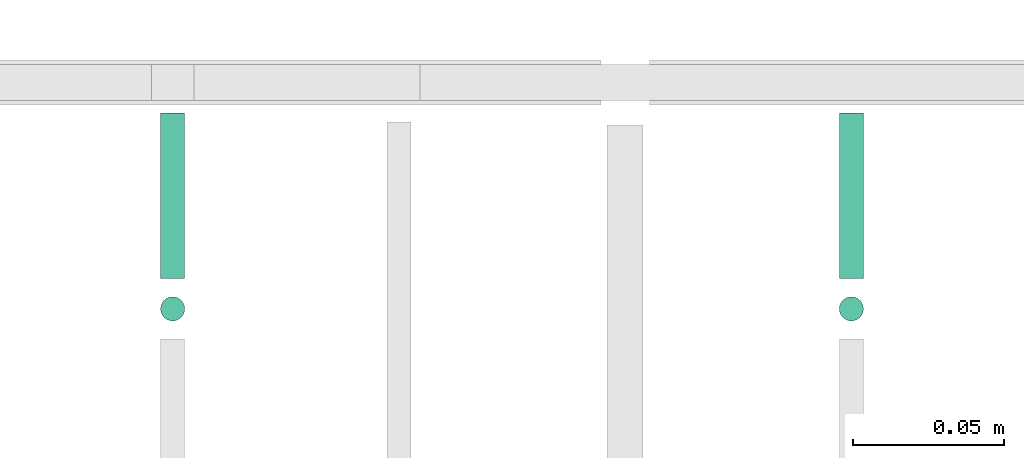
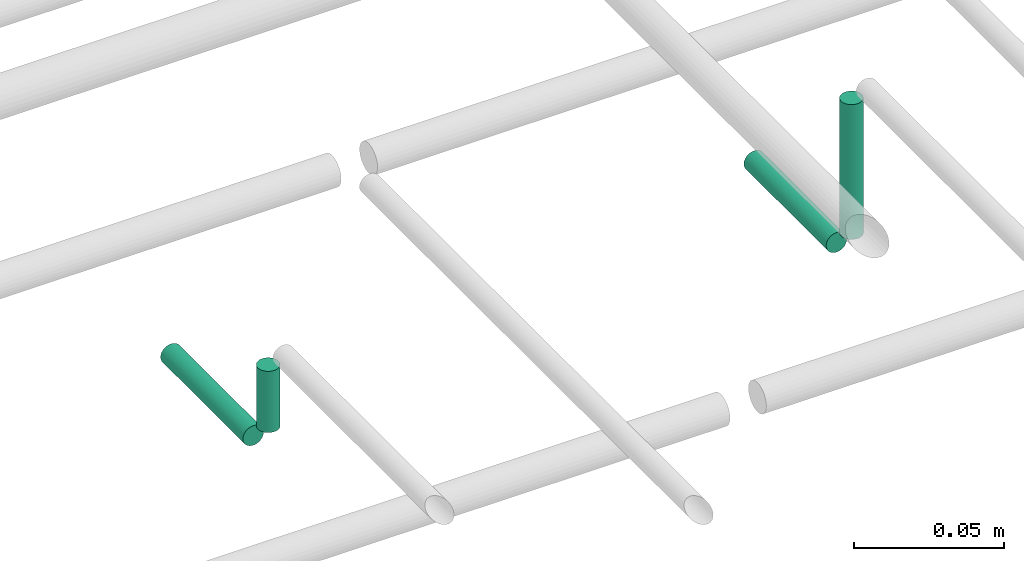
# One storey, part 261 of 331: 4 flow segments.
"""IFC2X3 building model written with IfcOpenShell, lengths in millimetres."""

from ifc_helpers import new_model, entity, si_unit, converted_unit, derived_unit, direction, frame, frame_2d, origin, origin_2d_with_axis, place, context, subcontext, project, spatial, circle, extrude, type_object, element, save


model = new_model("IFC2X3")

# Units and contexts
model_context = context("Model", 3, precision=0.01, world=origin(), true_north=direction((6.12303176911189e-17, 1.0)))
body_context = subcontext(model_context, "Body", "Model", "MODEL_VIEW")
ifc_project = project(units=[si_unit("LENGTHUNIT", "METRE", prefix="MILLI"), si_unit("AREAUNIT", "SQUARE_METRE"), si_unit("VOLUMEUNIT", "CUBIC_METRE"), converted_unit("PLANEANGLEUNIT", "DEGREE", entity("IfcRatioMeasure", 0.0174532925199433), si_unit("PLANEANGLEUNIT", "RADIAN"), dimensions=[0, 0, 0, 0, 0, 0, 0]), si_unit("MASSUNIT", "GRAM", prefix="KILO"), derived_unit("MASSDENSITYUNIT", [(si_unit("MASSUNIT", "GRAM", prefix="KILO"), 1), (si_unit("LENGTHUNIT", "METRE"), -3)]), derived_unit("MOMENTOFINERTIAUNIT", [(si_unit("LENGTHUNIT", "METRE"), 4)]), si_unit("TIMEUNIT", "SECOND"), si_unit("FREQUENCYUNIT", "HERTZ"), si_unit("THERMODYNAMICTEMPERATUREUNIT", "DEGREE_CELSIUS"), derived_unit("THERMALTRANSMITTANCEUNIT", [(si_unit("MASSUNIT", "GRAM", prefix="KILO"), 1), (si_unit("THERMODYNAMICTEMPERATUREUNIT", "KELVIN"), -1), (si_unit("TIMEUNIT", "SECOND"), -3)]), derived_unit("VOLUMETRICFLOWRATEUNIT", [(si_unit("LENGTHUNIT", "METRE"), 3), (si_unit("TIMEUNIT", "SECOND"), -1)]), derived_unit("MASSFLOWRATEUNIT", [(si_unit("MASSUNIT", "GRAM", prefix="KILO"), 1), (si_unit("TIMEUNIT", "SECOND"), -1)]), derived_unit("ROTATIONALFREQUENCYUNIT", [(si_unit("TIMEUNIT", "SECOND"), -1)]), si_unit("ELECTRICCURRENTUNIT", "AMPERE"), si_unit("ELECTRICVOLTAGEUNIT", "VOLT"), si_unit("POWERUNIT", "WATT"), si_unit("FORCEUNIT", "NEWTON", prefix="KILO"), si_unit("ILLUMINANCEUNIT", "LUX"), si_unit("LUMINOUSFLUXUNIT", "LUMEN"), si_unit("LUMINOUSINTENSITYUNIT", "CANDELA"), derived_unit("USERDEFINED", [(si_unit("MASSUNIT", "GRAM", prefix="KILO"), -1), (si_unit("LENGTHUNIT", "METRE"), -2), (si_unit("TIMEUNIT", "SECOND"), 3), (si_unit("LUMINOUSFLUXUNIT", "LUMEN"), 1)]), derived_unit("LINEARVELOCITYUNIT", [(si_unit("LENGTHUNIT", "METRE"), 1), (si_unit("TIMEUNIT", "SECOND"), -1)]), si_unit("PRESSUREUNIT", "PASCAL"), derived_unit("USERDEFINED", [(si_unit("LENGTHUNIT", "METRE"), -2), (si_unit("MASSUNIT", "GRAM", prefix="KILO"), 1), (si_unit("TIMEUNIT", "SECOND"), -2)]), derived_unit("LINEARFORCEUNIT", [(si_unit("MASSUNIT", "GRAM", prefix="KILO"), 1), (si_unit("LENGTHUNIT", "METRE"), 1), (si_unit("TIMEUNIT", "SECOND"), -2), (si_unit("LENGTHUNIT", "METRE"), -1)]), derived_unit("PLANARFORCEUNIT", [(si_unit("MASSUNIT", "GRAM", prefix="KILO"), 1), (si_unit("LENGTHUNIT", "METRE"), 1), (si_unit("TIMEUNIT", "SECOND"), -2), (si_unit("LENGTHUNIT", "METRE"), -2)])], contexts=[model_context])

# Site, building, storey
site_placement = place(None, frame((0.0, -0.00077364408347762, 0.0)))
site = spatial("IfcSite", under=ifc_project, at=site_placement, CompositionType="ELEMENT")
building_placement = place(site_placement, origin())
building = spatial("IfcBuilding", under=site, at=building_placement, CompositionType="ELEMENT")
storey_placement = place(building_placement, origin())
storey = spatial("IfcBuildingStorey", under=building, at=storey_placement, CompositionType="ELEMENT", Elevation=0.0)

# Flow segments
pipe_segment_type = type_object("IfcPipeSegmentType", PredefinedType="NOTDEFINED")
flow_segment_1_placement = place(building_placement, frame((34390.4558773093, 9194.40472776438, 18565.0)))
element("IfcFlowSegment", 1, at=flow_segment_1_placement, inside=storey, type_object=pipe_segment_type, context=body_context, shape_type="SweptSolid", body=[
    extrude(circle(Radius=4.0, at=origin_2d_with_axis()), frame((5.59527223591499, 5.59527223591607, 0.0), z_axis=(0.0, 0.0, 1.0), x_axis=(-1.0, 0.0, 0.0)), (0.0, 0.0, 1.0), 55.0000000000092),
])
flow_segment_2_placement = place(building_placement, frame((34165.4558773093, 9194.40472776435, 18565.0)))
element("IfcFlowSegment", 2, at=flow_segment_2_placement, inside=storey, type_object=pipe_segment_type, context=body_context, shape_type="SweptSolid", body=[
    extrude(circle(Radius=4.0, at=frame_2d((0.0, -1.08286712929839e-12), x_axis=(1.0, 0.0))), frame((5.59527223591499, 5.59527223591499, 0.0), z_axis=(0.0, 0.0, 1.0), x_axis=(-1.0, 0.0, 0.0)), (0.0, 0.0, 1.0), 24.9999999999986),
])
flow_segment_3_placement = place(building_placement, frame((34165.4558773093, 9210.0, 18549.4047277641)))
element("IfcFlowSegment", 3, at=flow_segment_3_placement, inside=storey, type_object=pipe_segment_type, context=body_context, shape_type="SweptSolid", body=[
    extrude(circle(Radius=4.0, at=frame_2d((-4.33146851719357e-12, 0.0), x_axis=(1.0, 0.0))), frame((5.59527223591499, 0.0, 5.59527223591499), z_axis=(0.0, 1.0, 0.0), x_axis=(-1.0, 0.0, 0.0)), (0.0, 0.0, 1.0), 55.0000000000546),
])
flow_segment_4_placement = place(building_placement, frame((34390.4558773093, 9210.0, 18549.4047277641)))
element("IfcFlowSegment", 4, at=flow_segment_4_placement, inside=storey, type_object=pipe_segment_type, context=body_context, shape_type="SweptSolid", body=[
    extrude(circle(Radius=4.0, at=origin_2d_with_axis()), frame((5.59527223591499, 0.0, 5.59527223591499), z_axis=(0.0, 1.0, 0.0), x_axis=(1.0, 0.0, 0.0)), (0.0, 0.0, 1.0), 55.0000000000178),
])

save(model, "model.ifc")
